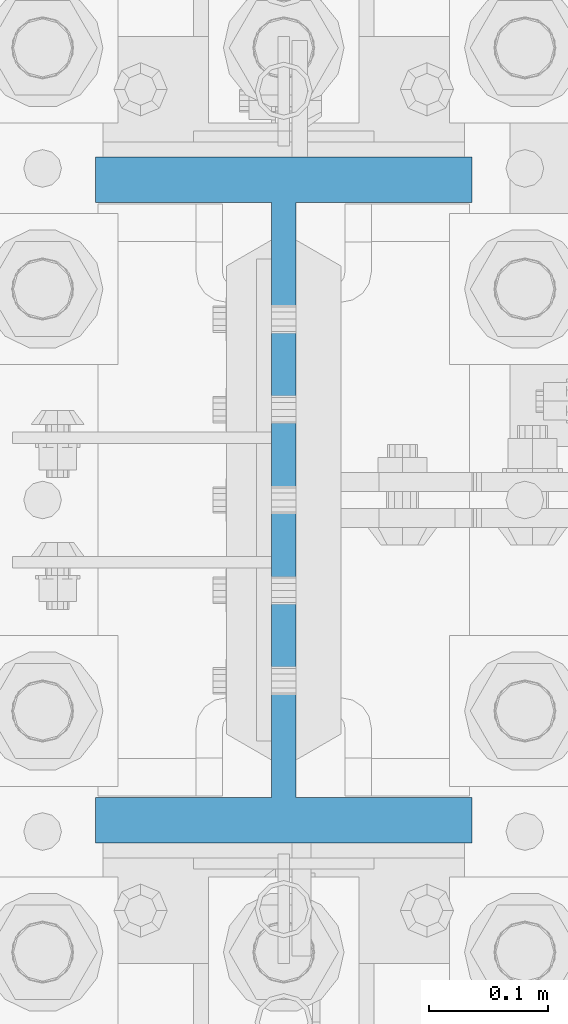
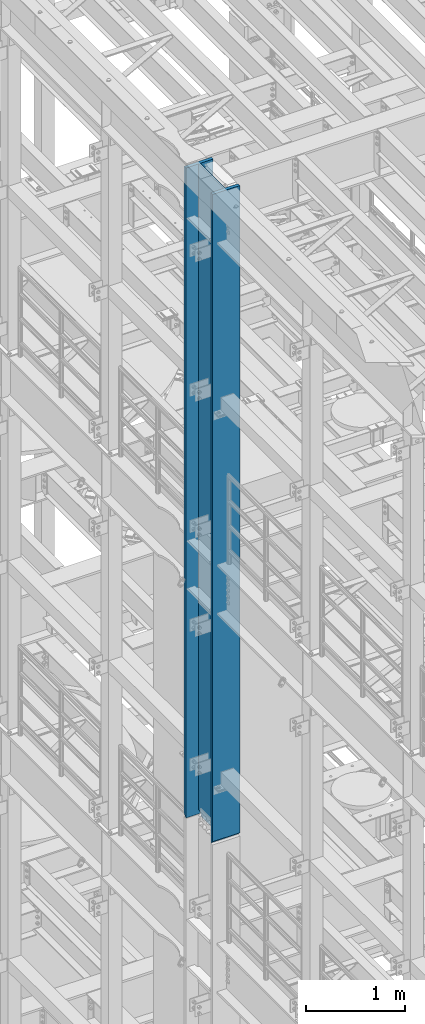
# One storey, part 686 of 1876: 1 column, 1 element without a shape of its own.
"""IFC2X3 building model written with IfcOpenShell, lengths in millimetres."""

import ifcopenshell
import ifcopenshell.guid

model = None  # the IFC model being written
_history = None  # IfcOwnerHistory: only IFC2X3 demands one
_inside = {}  # id of a spatial element -> (the spatial element, [elements in it])
_under = {}  # id of a project, library or spatial element -> (it, [spatial elements below it])
_declared = {}  # id of a project -> (the project, [libraries it declares])
_typed = {}  # id of a type object -> (the type object, [elements of that type])
_made_of = {}  # id of a material, layer set ... -> (it, [elements and type objects made of it])


def new_model(schema):
    """Start an empty IFC model of exactly this schema.

    Asked for "IFC4X3", IfcOpenShell would pick the latest addendum, in which some entities
    have other attributes; the version numbers below select the first issue.
    IFC2X3 requires an IfcOwnerHistory on every rooted entity: one is made here for all.
    """
    global model, _history
    if schema == "IFC4X3":
        model = ifcopenshell.file(schema_version=(4, 3, 0, 0))
    else:
        model = ifcopenshell.file(schema=schema)
    _inside.clear()
    _under.clear()
    _declared.clear()
    _typed.clear()
    _made_of.clear()
    _history = None
    if model.schema == "IFC2X3":
        org = make("IfcOrganization", Name="unknown")
        user = make(
            "IfcPersonAndOrganization",
            ThePerson=make("IfcPerson", FamilyName="unknown"),
            TheOrganization=org,
        )
        app = make(
            "IfcApplication",
            ApplicationDeveloper=org,
            Version="unknown",
            ApplicationFullName="unknown",
            ApplicationIdentifier="unknown",
        )
        _history = make(
            "IfcOwnerHistory",
            OwningUser=user,
            OwningApplication=app,
            ChangeAction="ADDED",
            CreationDate=0,
        )
    return model


def make(cls, **values):
    """One entity of the class cls with the attributes given. An attribute that is None is left unset."""
    return model.create_entity(
        cls, **{name: value for name, value in values.items() if value is not None}
    )


def rooted(cls, **values):
    """An entity with a GlobalId (a new one), such as an element, a storey or a relation."""
    return make(cls, GlobalId=ifcopenshell.guid.new(), OwnerHistory=_history, **values)


def si_unit(unit_type, name, prefix=None):
    """IfcSIUnit, for example si_unit("LENGTHUNIT", "METRE", prefix="MILLI")."""
    return make("IfcSIUnit", UnitType=unit_type, Prefix=prefix, Name=name)


def assignment(units):
    """IfcUnitAssignment: the units of a project."""
    return None if units is None else make("IfcUnitAssignment", Units=units)


def point(xyz):
    """IfcCartesianPoint."""
    return None if xyz is None else make("IfcCartesianPoint", Coordinates=xyz)


def direction(xyz):
    """IfcDirection."""
    return None if xyz is None else make("IfcDirection", DirectionRatios=xyz)


def frame(location, z_axis=None, x_axis=None):
    """IfcAxis2Placement3D, a coordinate frame: its origin and axes. An axis left out is left unset."""
    return make(
        "IfcAxis2Placement3D",
        Location=point(location),
        Axis=direction(z_axis),
        RefDirection=direction(x_axis),
    )


def origin_with_axes():
    """The frame at (0, 0, 0) with the z axis (0, 0, 1) and the x axis (1, 0, 0) written out."""
    return frame((0.0, 0.0, 0.0), z_axis=(0.0, 0.0, 1.0), x_axis=(1.0, 0.0, 0.0))


def place(relative_to, where):
    """IfcLocalPlacement: puts the frame where relative to a parent placement (None: the world)."""
    return make(
        "IfcLocalPlacement", PlacementRelTo=relative_to, RelativePlacement=where
    )


def context(
    kind, dimensions, precision=None, world=None, true_north=None, identifier=None
):
    """IfcGeometricRepresentationContext, for example the 3D "Model" context."""
    return make(
        "IfcGeometricRepresentationContext",
        ContextIdentifier=identifier,
        ContextType=kind,
        CoordinateSpaceDimension=dimensions,
        Precision=precision,
        WorldCoordinateSystem=world,
        TrueNorth=true_north,
    )


def subcontext(parent, identifier, kind, view, scale=None):
    """IfcGeometricRepresentationSubContext, for example "Body" below "Model"."""
    return make(
        "IfcGeometricRepresentationSubContext",
        ContextIdentifier=identifier,
        ContextType=kind,
        ParentContext=parent,
        TargetScale=scale,
        TargetView=view,
    )


def project(units=None, contexts=None):
    """IfcProject with its units and contexts."""
    return rooted(
        "IfcProject",
        Name="project",
        RepresentationContexts=contexts,
        UnitsInContext=assignment(units),
    )


def spatial(cls, under=None, at=None, **own):
    """A site, building, storey or space (cls), placed at a placement, below another one or the project."""
    s = rooted(cls, ObjectPlacement=at, **own)
    if under is not None:
        _under.setdefault(under.id(), (under, []))[1].append(s)
    return s


def faces_of(points, faces, orient=None, outer=None):
    """IfcFace entities. A face is a list of loops; a loop is a list of indices into points, from 0.

    orient and outer hold one flag for each loop. By default every Orientation is true, the
    first loop of a face is its IfcFaceOuterBound and the others are IfcFaceBound.
    """
    made = []
    for i, loops in enumerate(faces):
        bounds = []
        for j, loop in enumerate(loops):
            is_outer = j == 0 if outer is None else outer[i][j]
            bounds.append(
                make(
                    "IfcFaceOuterBound" if is_outer else "IfcFaceBound",
                    Bound=make("IfcPolyLoop", Polygon=[points[k] for k in loop]),
                    Orientation=True if orient is None else orient[i][j],
                )
            )
        made.append(make("IfcFace", Bounds=bounds))
    return made


def faceted_brep(points, faces, orient=None, outer=None, voids=None):
    """IfcFacetedBrep: a solid bounded by flat faces; with voids (closed shells), ...WithVoids."""
    shared = [point(p) for p in points]
    hull = make("IfcClosedShell", CfsFaces=faces_of(shared, faces, orient, outer))
    if voids is None:
        return make("IfcFacetedBrep", Outer=hull)
    return make(
        "IfcFacetedBrepWithVoids",
        Outer=hull,
        Voids=[
            make(cls, CfsFaces=faces_of(shared, fs, o, b)) for cls, fs, o, b in voids
        ],
    )


def shape(context_of_items, identifier, shape_type, items):
    """IfcShapeRepresentation: the items that make up one representation, for example the "Body"."""
    return make(
        "IfcShapeRepresentation",
        ContextOfItems=context_of_items,
        RepresentationIdentifier=identifier,
        RepresentationType=shape_type,
        Items=items,
    )


def material(Name=None, Category=None):
    """IfcMaterial."""
    return make("IfcMaterial", Name=Name, Category=Category)


def made_of(thing, what):
    """Note that an element or type object is made of a material, layer set ...; save() writes the relation."""
    if what is not None:
        _made_of.setdefault(what.id(), (what, []))[1].append(thing)
    return thing


def type_object(cls, material=None, **own):
    """A type object (cls), such as IfcWallType, which elements share."""
    return made_of(rooted(cls, **own), material)


def element(
    cls,
    number,
    at=None,
    inside=None,
    cuts=None,
    type_object=None,
    material=None,
    context=None,
    identifier="Body",
    shape_type=None,
    held_by="IfcProductDefinitionShape",
    body=None,
    shapes=None,
    **own,
):
    """One element of the class cls, such as IfcWall. Its Tag is "e" and its number.

    at: its placement. inside: the storey or other place that contains it. cuts: it is an
    opening in that element (IfcRelVoidsElement). A single representation is given by context,
    identifier, shape_type and body (its items); several are given by shapes. held_by: the class
    of the entity that holds the representations. save() writes the other relations.
    """
    e = rooted(cls, Tag="e%d" % number, ObjectPlacement=at, **own)
    if body is not None:
        shapes = [shape(context, identifier, shape_type, body)]
    if shapes is not None:
        e.Representation = make(held_by, Representations=shapes)
    if inside is not None:
        _inside.setdefault(inside.id(), (inside, []))[1].append(e)
    if cuts is not None:
        rooted(
            "IfcRelVoidsElement", RelatingBuildingElement=cuts, RelatedOpeningElement=e
        )
    if type_object is not None:
        _typed.setdefault(type_object.id(), (type_object, []))[1].append(e)
    return made_of(e, material)


def aggregate(whole, parts):
    """IfcRelAggregates: a whole, such as a stair, and the parts it consists of."""
    return rooted("IfcRelAggregates", RelatingObject=whole, RelatedObjects=parts)


def save(model, path):
    """Write the relations noted so far, then the file.

    IfcRelAggregates (storeys below a building ...), IfcRelContainedInSpatialStructure (elements
    in a storey), IfcRelDefinesByType, IfcRelAssociatesMaterial and IfcRelDeclares: one each for
    every whole, place, type object, material and project.
    """
    for whole, parts in _under.values():
        aggregate(whole, parts)
    for where, things in _inside.values():
        rooted(
            "IfcRelContainedInSpatialStructure",
            RelatedElements=things,
            RelatingStructure=where,
        )
    for kind, things in _typed.values():
        rooted("IfcRelDefinesByType", RelatedObjects=things, RelatingType=kind)
    for what, things in _made_of.values():
        rooted("IfcRelAssociatesMaterial", RelatedObjects=things, RelatingMaterial=what)
    for by, libraries in _declared.values():
        rooted("IfcRelDeclares", RelatingContext=by, RelatedDefinitions=libraries)
    model.write(path)


model = new_model("IFC2X3")

# Units and contexts
model_context = context("Model", 3, precision=1e-05, world=origin_with_axes())
body_context = subcontext(model_context, "Body", "Model", "MODEL_VIEW")
ifc_project = project(units=[si_unit("LENGTHUNIT", "METRE", prefix="MILLI"), si_unit("AREAUNIT", "SQUARE_METRE"), si_unit("VOLUMEUNIT", "CUBIC_METRE"), si_unit("MASSUNIT", "GRAM", prefix="KILO"), si_unit("TIMEUNIT", "SECOND"), si_unit("PLANEANGLEUNIT", "RADIAN"), si_unit("SOLIDANGLEUNIT", "STERADIAN"), si_unit("THERMODYNAMICTEMPERATUREUNIT", "DEGREE_CELSIUS"), si_unit("LUMINOUSINTENSITYUNIT", "LUMEN")], contexts=[model_context])

# Site, building, storey
site_placement = place(None, origin_with_axes())
site = spatial("IfcSite", under=ifc_project, at=site_placement, CompositionType="ELEMENT")
building_placement = place(site_placement, origin_with_axes())
building = spatial("IfcBuilding", under=site, at=building_placement, Name="Undefined", CompositionType="ELEMENT")
storey_placement = place(building_placement, origin_with_axes())
storey = spatial("IfcBuildingStorey", under=building, at=storey_placement, Name="Undefined", CompositionType="ELEMENT", Elevation=0.0)

# Assembly, column
assembly_placement = place(storey_placement, origin_with_axes())
assembly = element("IfcElementAssembly", 1, at=assembly_placement, inside=storey, Name="COLUMN", AssemblyPlace="NOTDEFINED", PredefinedType="RIGID_FRAME")
ifc_material = material(Name="STEEL/A992")
column_type = type_object("IfcColumnType", Name="W21X182", PredefinedType="NOTDEFINED")
column_placement = place(assembly_placement, frame((0.0, 1524.0, 14528.8), z_axis=(0.0, 1.0, 0.0), x_axis=(0.0, 0.0, 1.0)))
column = element("IfcColumn", 2, at=column_placement, type_object=column_type, material=ifc_material, Name="COLUMN", ObjectType="W21X182", context=body_context, shape_type="Brep", body=[
    faceted_brep([(23.8124996185306, 10.31875, 203.498507902428), (23.8124996185306, 10.31875, -203.49850776611), (6.35000000000036, -7.14374961853027, -200.025000762939), (6.35000000000036, -7.14374961853027, 200.025000762939), (8026.4, 158.75, -288.925), (8026.4, -158.75, -288.925), (41.2749999999833, -158.75, -288.925), (41.2749999999833, 158.75, -288.925), (8026.4, -158.75, -250.825), (57.149999999996, -158.75, -250.825), (6.35000000000036, -158.75, -250.825), (6.35000000000036, -158.75, -254.000000000019), (57.149999999996, -10.3187500000004, -250.825), (6.35000000000036, -10.3187500000004, -250.825), (8026.4, -10.3187500000004, -250.825), (6.35000000000036, -158.75, 250.825), (57.1499992370573, -158.75, 250.825), (8026.4, -158.75, 250.825), (8026.4, -158.75, 288.925), (41.2749999999833, -158.75, 288.925), (6.35000000000036, -158.75, 254.00000000002), (8026.4, 158.75, 288.925), (41.2749999999833, 158.75, 288.925), (6.35000000000036, 158.75, 254.00000000002), (8026.4, 158.75, 250.825), (57.1499992370573, 158.75, 250.825), (6.35000000000036, 158.75, 250.825), (6.35000000000036, -10.3187500000004, 250.825), (6.35000000000036, 10.3187500000004, 250.825), (6.35000000000036, -7.14374961853027, 250.825), (57.1499992370573, -10.3187500000004, 250.825), (8026.4, -10.3187500000004, 250.825), (53.2830795467053, -10.3187500000004, 231.384681927818), (42.2710239447933, -10.3187500000004, 214.903976055203), (25.7903180721787, -10.3187500000004, 203.891920453291), (6.35000000000036, -10.31875, 200.025000762939), (6.35000000000036, -10.31875, -200.025000762939), (25.7903188351174, -10.3187500000004, -203.891920453291), (42.2710247077321, -10.3187500000004, -214.903976055203), (53.283080309644, -10.3187500000004, -231.384681927818), (25.7903188351174, 10.3187500000004, -203.891920453291), (42.2710247077321, 10.3187500000004, -214.903976055203), (53.283080309644, 10.3187500000004, -231.384681927818), (57.1499999999978, 10.3187500000004, -250.825), (57.149999999996, 158.75, -250.825), (6.35000000000036, 158.75, -250.825), (6.35000000000036, 10.3187500000004, -250.825), (23.8124996185306, 10.31875, -250.825), (8026.4, 10.3187500000004, -250.825), (8026.4, 158.75, -250.825), (6.35000000000036, -7.14374961853027, -250.825), (6.35000000000036, 158.75, -254.000000000019), (8026.4, 10.3187500000004, 250.825), (57.1499992370573, 10.3187500000004, 250.825), (23.8124996185306, 10.31875, 250.825), (53.2830795467053, 10.3187500000004, 231.384681927818), (42.2710239447933, 10.3187500000004, 214.903976055203), (25.7903180721787, 10.3187500000004, 203.891920453291)], [[[0, 1, 2, 3]], [[4, 5, 6, 7]], [[5, 8, 9, 10, 11, 6]], [[12, 13, 10, 9, 8, 14]], [[15, 16, 17, 18, 19, 20]], [[18, 21, 22, 19]], [[19, 22, 23, 20]], [[21, 24, 25, 26, 23, 22]], [[27, 15, 20, 23, 26, 28, 29]], [[16, 15, 27, 30, 31, 17]], [[14, 31, 30, 32, 33, 34, 35, 36, 37, 38, 39, 12]], [[37, 40, 41, 38]], [[38, 41, 42, 39]], [[39, 42, 43, 12]], [[44, 45, 46, 47, 43, 48, 49]], [[12, 43, 47, 46, 50, 13]], [[46, 45, 51, 11, 10, 13, 50]], [[6, 11, 51, 7]], [[45, 44, 49, 4, 7, 51]], [[48, 52, 24, 21, 18, 17, 31, 14, 8, 5, 4, 49]], [[53, 54, 28, 26, 25, 24, 52]], [[27, 29, 28, 54, 53, 30]], [[30, 53, 55, 32]], [[32, 55, 56, 33]], [[33, 56, 57, 34]], [[35, 34, 57, 0, 3]], [[36, 35, 3, 2]], [[40, 37, 36, 2, 1]], [[57, 56, 55, 53, 52, 48, 43, 42, 41, 40, 1, 0]]]),
])
aggregate(assembly, [column])

save(model, "model.ifc")
